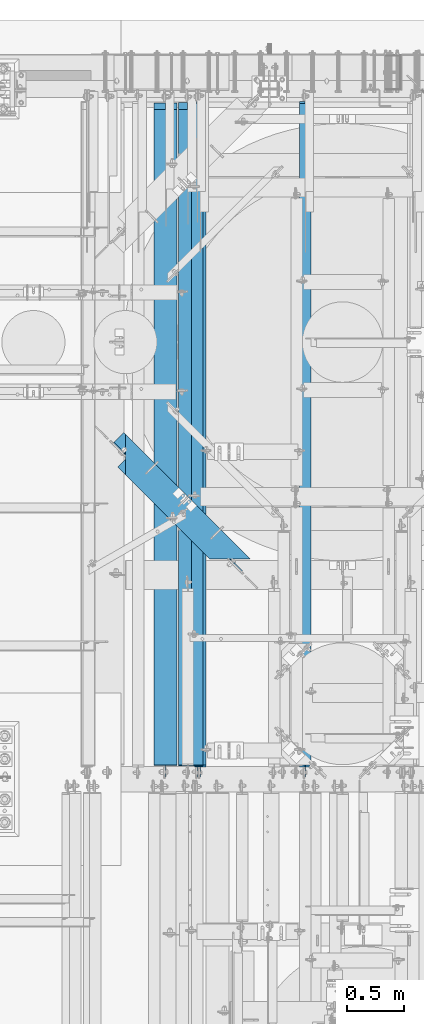
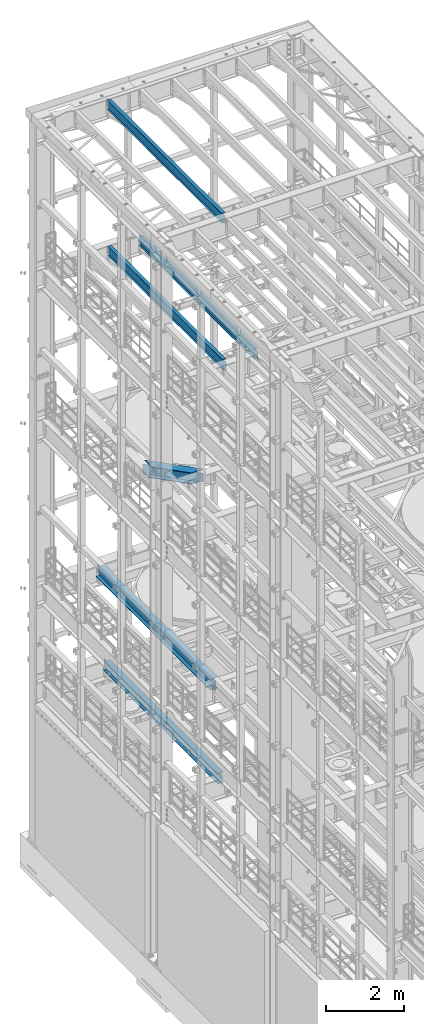
# One storey, part 1051 of 1876: 6 beams, 6 elements without a shape of their own.
"""IFC2X3 building model written with IfcOpenShell, lengths in millimetres."""

from ifc_helpers import new_model, si_unit, frame, origin_with_axes, place, context, subcontext, project, spatial, faceted_brep, material, type_object, element, aggregate, save


model = new_model("IFC2X3")

# Units and contexts
model_context = context("Model", 3, precision=1e-05, world=origin_with_axes())
body_context = subcontext(model_context, "Body", "Model", "MODEL_VIEW")
ifc_project = project(units=[si_unit("LENGTHUNIT", "METRE", prefix="MILLI"), si_unit("AREAUNIT", "SQUARE_METRE"), si_unit("VOLUMEUNIT", "CUBIC_METRE"), si_unit("MASSUNIT", "GRAM", prefix="KILO"), si_unit("TIMEUNIT", "SECOND"), si_unit("PLANEANGLEUNIT", "RADIAN"), si_unit("SOLIDANGLEUNIT", "STERADIAN"), si_unit("THERMODYNAMICTEMPERATUREUNIT", "DEGREE_CELSIUS"), si_unit("LUMINOUSINTENSITYUNIT", "LUMEN")], contexts=[model_context])

# Site, building, storey
site_placement = place(None, origin_with_axes())
site = spatial("IfcSite", under=ifc_project, at=site_placement, CompositionType="ELEMENT")
building_placement = place(site_placement, origin_with_axes())
building = spatial("IfcBuilding", under=site, at=building_placement, Name="Undefined", CompositionType="ELEMENT")
storey_placement = place(building_placement, origin_with_axes())
storey = spatial("IfcBuildingStorey", under=building, at=storey_placement, Name="Undefined", CompositionType="ELEMENT", Elevation=0.0)

# Assembly, beam
assembly_1_placement = place(storey_placement, origin_with_axes())
assembly_1 = element("IfcElementAssembly", 1, at=assembly_1_placement, inside=storey, Name="BEAM", AssemblyPlace="NOTDEFINED", PredefinedType="RIGID_FRAME")
ifc_material = material(Name="STEEL/A992")
beam_type_1 = type_object("IfcBeamType", Name="W12X16", PredefinedType="NOTDEFINED")
beam_1_placement = place(assembly_1_placement, frame((2857.5, 7620.0, 17830.8), z_axis=(0.0, 0.0, 1.0), x_axis=(0.0, 1.0, 0.0)))
beam_1 = element("IfcBeam", 2, at=beam_1_placement, type_object=beam_type_1, material=ifc_material, Name="BEAM", ObjectType="W12X16", context=body_context, shape_type="Brep", body=[
    faceted_brep([(19.84375, -3.17499999999995, -126.999999999996), (19.84375, 3.17499999999995, -126.999999999996), (96.0437501907345, 3.17500002364682, -126.999999999996), (96.0437501907345, -3.17499999999995, -126.999999999996), (100.90382970878, 3.17500002380461, -127.966729922584), (100.90382970878, -3.17499999999995, -127.966729922584), (105.024006176934, 3.17500002425209, -130.719743823061), (105.024006176934, -3.17499999999995, -130.719743823061), (107.777020077412, 3.17500002492102, -134.839920291215), (107.777020077412, -3.17499999999995, -134.839920291215), (108.74375, -3.17499999999995, -139.699999809261), (108.74375, 3.17500002570978, -139.699999809261), (108.74375, 3.17500009516311, -146.049999999999), (108.74375, 50.8, -146.049999999999), (108.74375, 50.8, -152.400000000001), (108.74375, -50.8, -152.400000000001), (108.74375, -50.8, -146.049999999999), (108.74375, -3.17499999999995, -146.049999999999), (5969.79375, 50.8, 146.049999999999), (5969.79375, 3.17499999999995, 146.049999999999), (126.20625, 3.17499999999995, 146.049999999999), (126.20625, 50.8, 146.049999999999), (113.506250190735, -3.17499999999995, 107.950000000004), (113.506250190735, 3.17499998606149, 107.950000000004), (19.84375, 3.17499999999995, 107.950000000004), (19.84375, -3.17499999999995, 107.950000000004), (118.366329708781, -3.17499999999995, 108.916729922592), (118.366329708781, 3.17499998590552, 108.916729922592), (122.486506176934, -3.17499999999995, 111.669743823069), (122.486506176934, 3.17499998546009, 111.669743823069), (125.239520077413, -3.17499999999995, 115.789920291223), (125.239520077413, 3.17499998479298, 115.789920291223), (126.20625, -3.17499999999995, 120.64999980927), (126.20625, 3.17499998400558, 120.64999980927), (5969.79375, -50.8, 152.400000000001), (5969.79375, 50.8, 152.400000000001), (126.20625, 50.8, 152.400000000001), (126.20625, -50.8, 152.400000000001), (5969.79375, -50.8, 146.049999999999), (126.20625, -50.8, 146.049999999999), (5969.79375, -3.17499999999995, 146.049999999999), (126.20625, -3.17499999999995, 146.049999999999), (5969.79375, -3.17499999999995, 120.64999980927), (5969.79375, 3.17499999999995, 120.64999980927), (5970.76047992259, -3.17499999999995, 115.789920291223), (5970.76047992259, 3.17499999999995, 115.789920291223), (5973.51349382307, -3.17499999999995, 111.669743823069), (5973.51349382307, 3.17499999999995, 111.669743823069), (5977.63367029122, -3.17499999999995, 108.916729922592), (5977.63367029122, 3.17499999999995, 108.916729922592), (5982.49374980927, -3.17499999999995, 107.950000000004), (5982.49374980927, 3.17499999999995, 107.950000000004), (6076.15625, -3.17499999999995, 107.950000000004), (6076.15625, 3.17499999999995, 107.950000000004), (6076.15625, -3.17499999999995, -126.999999999996), (6076.15625, 3.17499999999995, -126.999999999996), (5999.95624980926, -3.17499999999995, -126.999999999996), (5999.95624980926, 3.17499999999995, -126.999999999996), (5995.09617029122, -3.17499999999995, -127.966729922584), (5995.09617029122, 3.17499999999995, -127.966729922584), (5990.97599382306, -3.17499999999995, -130.719743823061), (5990.97599382306, 3.17499999999995, -130.719743823061), (5988.22297992259, -3.17499999999995, -134.839920291215), (5988.22297992259, 3.17499999999995, -134.839920291215), (5987.25625, -3.17499999999995, -139.699999809261), (5987.25625, 3.17499999999995, -139.699999809261), (5987.25625, -3.17499999999995, -146.049999999999), (5987.25625, -50.8, -146.049999999999), (5987.25625, -50.8, -152.400000000001), (5987.25625, 50.8, -152.400000000001), (5987.25625, 50.8, -146.049999999999), (5987.25625, 3.17499999999995, -146.049999999999)], [[[0, 1, 2, 3]], [[3, 2, 4, 5]], [[5, 4, 6, 7]], [[7, 6, 8, 9]], [[10, 11, 12, 13, 14, 15, 16, 17]], [[9, 8, 11, 10]], [[18, 19, 20, 21]], [[22, 23, 24, 25]], [[26, 27, 23, 22]], [[28, 29, 27, 26]], [[30, 31, 29, 28]], [[32, 33, 31, 30]], [[34, 35, 36, 37]], [[38, 34, 37, 39]], [[40, 38, 39, 41]], [[37, 36, 21, 20, 33, 32, 41, 39]], [[35, 18, 21, 36]], [[34, 38, 40, 42, 43, 19, 18, 35]], [[44, 45, 43, 42]], [[46, 47, 45, 44]], [[48, 49, 47, 46]], [[50, 51, 49, 48]], [[52, 53, 51, 50]], [[53, 52, 54, 55]], [[54, 56, 57, 55]], [[58, 59, 57, 56]], [[60, 61, 59, 58]], [[62, 63, 61, 60]], [[64, 65, 63, 62]], [[66, 67, 68, 69, 70, 71, 65, 64]], [[67, 66, 17, 16]], [[68, 67, 16, 15]], [[69, 68, 15, 14]], [[70, 69, 14, 13]], [[71, 70, 13, 12]], [[6, 4, 2, 1, 24, 23, 27, 29, 31, 33, 20, 19, 43, 45, 47, 49, 51, 53, 55, 57, 59, 61, 63, 65, 71, 12, 11, 8]], [[25, 24, 1, 0]], [[66, 64, 62, 60, 58, 56, 54, 52, 50, 48, 46, 44, 42, 40, 41, 32, 30, 28, 26, 22, 25, 0, 3, 5, 7, 9, 10, 17]]]),
])
aggregate(assembly_1, [beam_1])

assembly_2_placement = place(storey_placement, origin_with_axes())
assembly_2 = element("IfcElementAssembly", 3, at=assembly_2_placement, inside=storey, Name="BEAM", AssemblyPlace="NOTDEFINED", PredefinedType="RIGID_FRAME")
beam_2_placement = place(assembly_2_placement, frame((1930.4, 7620.0, 17830.8), z_axis=(0.0, 0.0, 1.0), x_axis=(0.0, 1.0, 0.0)))
beam_2 = element("IfcBeam", 4, at=beam_2_placement, type_object=beam_type_1, material=ifc_material, Name="BEAM", ObjectType="W12X16", context=body_context, shape_type="Brep", body=[
    faceted_brep([(19.84375, -3.17499999999995, -126.999999999996), (19.84375, 3.17499999999995, -126.999999999996), (96.0437501907345, 3.17500002364682, -126.999999999996), (96.0437501907345, -3.17499999999995, -126.999999999996), (100.90382970878, 3.17500002380461, -127.966729922584), (100.90382970878, -3.17499999999995, -127.966729922584), (105.024006176934, 3.17500002425209, -130.719743823061), (105.024006176934, -3.17499999999995, -130.719743823061), (107.777020077412, 3.17500002492102, -134.839920291215), (107.777020077412, -3.17499999999995, -134.839920291215), (108.74375, -3.17499999999995, -139.699999809261), (108.74375, 3.17500002570978, -139.699999809261), (108.74375, 3.17500009516311, -146.049999999999), (108.74375, 50.8, -146.049999999999), (108.74375, 50.8, -152.400000000001), (108.74375, -50.8, -152.400000000001), (108.74375, -50.8, -146.049999999999), (108.74375, -3.17499999999995, -146.049999999999), (5969.79375, 50.8, 146.049999999999), (5969.79375, 3.17499999999995, 146.049999999999), (126.20625, 3.17499999999995, 146.049999999999), (126.20625, 50.8, 146.049999999999), (113.506250190735, -3.17499999999995, 107.950000000004), (113.506250190735, 3.17499998606149, 107.950000000004), (19.84375, 3.17499999999995, 107.950000000004), (19.84375, -3.17499999999995, 107.950000000004), (118.366329708781, -3.17499999999995, 108.916729922592), (118.366329708781, 3.17499998590552, 108.916729922592), (122.486506176934, -3.17499999999995, 111.669743823069), (122.486506176934, 3.17499998546009, 111.669743823069), (125.239520077413, -3.17499999999995, 115.789920291223), (125.239520077413, 3.17499998479298, 115.789920291223), (126.20625, -3.17499999999995, 120.64999980927), (126.20625, 3.17499998400558, 120.64999980927), (5969.79375, -50.8, 152.400000000001), (5969.79375, 50.8, 152.400000000001), (126.20625, 50.8, 152.400000000001), (126.20625, -50.8, 152.400000000001), (5969.79375, -50.8, 146.049999999999), (126.20625, -50.8, 146.049999999999), (5969.79375, -3.17499999999995, 146.049999999999), (126.20625, -3.17499999999995, 146.049999999999), (5969.79375, -3.17499999999995, 120.64999980927), (5969.79375, 3.17499999999995, 120.64999980927), (5970.76047992259, -3.17499999999995, 115.789920291223), (5970.76047992259, 3.17499999999995, 115.789920291223), (5973.51349382307, -3.17499999999995, 111.669743823069), (5973.51349382307, 3.17499999999995, 111.669743823069), (5977.63367029122, -3.17499999999995, 108.916729922592), (5977.63367029122, 3.17499999999995, 108.916729922592), (5982.49374980927, -3.17499999999995, 107.950000000004), (5982.49374980927, 3.17499999999995, 107.950000000004), (6076.15625, -3.17499999999995, 107.950000000004), (6076.15625, 3.17499999999995, 107.950000000004), (6076.15625, -3.17499999999995, -126.999999999996), (6076.15625, 3.17499999999995, -126.999999999996), (5999.95624980926, -3.17499999999995, -126.999999999996), (5999.95624980926, 3.17499999999995, -126.999999999996), (5995.09617029122, -3.17499999999995, -127.966729922584), (5995.09617029122, 3.17499999999995, -127.966729922584), (5990.97599382306, -3.17499999999995, -130.719743823061), (5990.97599382306, 3.17499999999995, -130.719743823061), (5988.22297992259, -3.17499999999995, -134.839920291215), (5988.22297992259, 3.17499999999995, -134.839920291215), (5987.25625, -3.17499999999995, -139.699999809261), (5987.25625, 3.17499999999995, -139.699999809261), (5987.25625, -3.17499999999995, -146.049999999999), (5987.25625, -50.8, -146.049999999999), (5987.25625, -50.8, -152.400000000001), (5987.25625, 50.8, -152.400000000001), (5987.25625, 50.8, -146.049999999999), (5987.25625, 3.17499999999995, -146.049999999999)], [[[0, 1, 2, 3]], [[3, 2, 4, 5]], [[5, 4, 6, 7]], [[7, 6, 8, 9]], [[10, 11, 12, 13, 14, 15, 16, 17]], [[9, 8, 11, 10]], [[18, 19, 20, 21]], [[22, 23, 24, 25]], [[26, 27, 23, 22]], [[28, 29, 27, 26]], [[30, 31, 29, 28]], [[32, 33, 31, 30]], [[34, 35, 36, 37]], [[38, 34, 37, 39]], [[40, 38, 39, 41]], [[37, 36, 21, 20, 33, 32, 41, 39]], [[35, 18, 21, 36]], [[34, 38, 40, 42, 43, 19, 18, 35]], [[44, 45, 43, 42]], [[46, 47, 45, 44]], [[48, 49, 47, 46]], [[50, 51, 49, 48]], [[52, 53, 51, 50]], [[53, 52, 54, 55]], [[54, 56, 57, 55]], [[58, 59, 57, 56]], [[60, 61, 59, 58]], [[62, 63, 61, 60]], [[64, 65, 63, 62]], [[66, 67, 68, 69, 70, 71, 65, 64]], [[67, 66, 17, 16]], [[68, 67, 16, 15]], [[69, 68, 15, 14]], [[70, 69, 14, 13]], [[71, 70, 13, 12]], [[6, 4, 2, 1, 24, 23, 27, 29, 31, 33, 20, 19, 43, 45, 47, 49, 51, 53, 55, 57, 59, 61, 63, 65, 71, 12, 11, 8]], [[25, 24, 1, 0]], [[66, 64, 62, 60, 58, 56, 54, 52, 50, 48, 46, 44, 42, 40, 41, 32, 30, 28, 26, 22, 25, 0, 3, 5, 7, 9, 10, 17]]]),
])
aggregate(assembly_2, [beam_2])

assembly_3_placement = place(storey_placement, origin_with_axes())
assembly_3 = element("IfcElementAssembly", 5, at=assembly_3_placement, inside=storey, Name="BEAM", AssemblyPlace="NOTDEFINED", PredefinedType="RIGID_FRAME")
beam_3_placement = place(assembly_3_placement, frame((1905.0, 7620.0, 22402.8), z_axis=(0.0, 0.0, 1.0), x_axis=(0.0, 1.0, 0.0)))
beam_3 = element("IfcBeam", 6, at=beam_3_placement, type_object=beam_type_1, material=ifc_material, Name="BEAM", ObjectType="W12X16", context=body_context, shape_type="Brep", body=[
    faceted_brep([(19.84375, -3.17499999999995, -126.999999999996), (19.84375, 3.17499999999995, -126.999999999996), (102.393750190735, 3.17500000000018, -127.000000000001), (102.393750190735, -3.17500000000018, -127.000000000001), (107.25382970878, 3.17500000000018, -127.966729922588), (107.25382970878, -3.17500000000018, -127.966729922588), (111.374006176934, 3.17500000000018, -130.719743823067), (111.374006176934, -3.17500000000018, -130.719743823067), (114.127020077412, 3.17500000000018, -134.839920291221), (114.127020077412, -3.17500000000018, -134.839920291221), (115.09375, -3.17500000000018, -139.699999809266), (115.09375, 3.17500000000018, -139.699999809266), (115.09375, 3.17500000000018, -146.05), (115.09375, 50.8000000000002, -146.05), (115.09375, 50.8000000000002, -152.4), (115.09375, -50.8000000000002, -152.4), (115.09375, -50.8000000000002, -146.05), (115.09375, -3.17500000000018, -146.05), (127.79375, 3.17500000000018, 146.05), (127.79375, 50.8000000000002, 146.05), (5968.20625, 50.8, 146.05), (5968.20625, 3.17499999999995, 146.05), (115.093750190735, -3.17500000000018, 114.299999999999), (115.093750190735, 3.17500000000018, 114.299999999999), (19.84375, 3.17500000000018, 114.299999999999), (19.84375, -3.17500000000018, 114.299999999999), (119.95382970878, -3.17500000000018, 115.266729922587), (119.95382970878, 3.17500000000018, 115.266729922587), (124.074006176934, -3.17500000000018, 118.019743823065), (124.074006176934, 3.17500000000018, 118.019743823065), (126.827020077412, -3.17500000000018, 122.139920291219), (126.827020077412, 3.17500000000018, 122.139920291219), (127.79375, -3.17500000000018, 126.999999809264), (127.79375, 3.17500000000018, 126.999999809264), (127.79375, 50.8000000000002, 152.4), (127.79375, -50.8000000000002, 152.4), (5968.20625, -50.8, 152.4), (5968.20625, 50.8, 152.4), (127.79375, -50.8000000000002, 146.05), (5968.20625, -50.8, 146.05), (127.79375, -3.17500000000018, 146.05), (5968.20625, -3.17499999999995, 146.05), (5968.20625, -3.17499999999995, 126.999999809264), (5968.20625, 3.17499999999995, 126.999999809264), (5969.17297992259, -3.17499999999995, 122.139920291219), (5969.17297992259, 3.17499999999995, 122.139920291219), (5971.92599382307, -3.17499999999995, 118.019743823065), (5971.92599382307, 3.17499999999995, 118.019743823065), (5976.04617029122, -3.17499999999995, 115.266729922587), (5976.04617029122, 3.17499999999995, 115.266729922587), (5980.90624980927, -3.17499999999995, 114.299999999999), (5980.90624980927, 3.17499999999995, 114.299999999999), (6076.15625, -3.17499999999995, 114.299999999999), (6076.15625, 3.17499999999995, 114.299999999999), (6076.15625, -3.17499999999995, -126.999999999996), (6076.15625, 3.17499999999995, -126.999999999996), (5993.60624980927, -3.17499999999995, -127.000000000001), (5993.60624980927, 3.17499999999995, -127.000000000001), (5988.74617029122, -3.17499999999995, -127.966729922588), (5988.74617029122, 3.17499999999995, -127.966729922588), (5984.62599382307, -3.17499999999995, -130.719743823067), (5984.62599382307, 3.17499999999995, -130.719743823067), (5981.87297992259, -3.17499999999995, -134.839920291221), (5981.87297992259, 3.17499999999995, -134.839920291221), (5980.90625, -3.17499999999995, -139.699999809266), (5980.90625, 3.17499999999995, -139.699999809266), (5980.90625, -3.17499999999995, -146.05), (5980.90625, -50.8, -146.05), (5980.90625, -50.8, -152.4), (5980.90625, 50.8, -152.4), (5980.90625, 50.8, -146.05), (5980.90625, 3.17499999999995, -146.05)], [[[0, 1, 2, 3]], [[3, 2, 4, 5]], [[5, 4, 6, 7]], [[7, 6, 8, 9]], [[10, 11, 12, 13, 14, 15, 16, 17]], [[9, 8, 11, 10]], [[18, 19, 20, 21]], [[22, 23, 24, 25]], [[26, 27, 23, 22]], [[28, 29, 27, 26]], [[30, 31, 29, 28]], [[32, 33, 31, 30]], [[34, 35, 36, 37]], [[35, 38, 39, 36]], [[38, 40, 41, 39]], [[35, 34, 19, 18, 33, 32, 40, 38]], [[19, 34, 37, 20]], [[36, 39, 41, 42, 43, 21, 20, 37]], [[44, 45, 43, 42]], [[46, 47, 45, 44]], [[48, 49, 47, 46]], [[50, 51, 49, 48]], [[52, 53, 51, 50]], [[53, 52, 54, 55]], [[54, 56, 57, 55]], [[58, 59, 57, 56]], [[60, 61, 59, 58]], [[62, 63, 61, 60]], [[64, 65, 63, 62]], [[66, 67, 68, 69, 70, 71, 65, 64]], [[17, 16, 67, 66]], [[16, 15, 68, 67]], [[15, 14, 69, 68]], [[14, 13, 70, 69]], [[13, 12, 71, 70]], [[59, 61, 63, 65, 71, 12, 11, 8, 6, 4, 2, 1, 24, 23, 27, 29, 31, 33, 18, 21, 43, 45, 47, 49, 51, 53, 55, 57]], [[25, 24, 1, 0]], [[52, 50, 48, 46, 44, 42, 41, 40, 32, 30, 28, 26, 22, 25, 0, 3, 5, 7, 9, 10, 17, 66, 64, 62, 60, 58, 56, 54]]]),
])
aggregate(assembly_3, [beam_3])

assembly_4_placement = place(storey_placement, origin_with_axes())
assembly_4 = element("IfcElementAssembly", 7, at=assembly_4_placement, inside=storey, Name="BEAM", AssemblyPlace="NOTDEFINED", PredefinedType="RIGID_FRAME")
beam_type_2 = type_object("IfcBeamType", Name="W12X30", PredefinedType="NOTDEFINED")
beam_4_placement = place(assembly_4_placement, frame((1822.45, 7620.0000000019, 4973.6375), z_axis=(0.0, 0.0, 1.0), x_axis=(0.0, 1.0, 0.0)))
beam_4 = element("IfcBeam", 8, at=beam_4_placement, type_object=beam_type_2, material=ifc_material, Name="BEAM", ObjectType="W12X30", context=body_context, shape_type="Brep", body=[
    faceted_brep([(19.8437500000002, -3.17500000000018, -131.762499999993), (19.8437500000002, 3.17500000000018, -131.762499999993), (102.393750190735, 3.17500000000018, -131.762500000001), (102.393750190735, -3.17500000000018, -131.762500000001), (107.25382970878, 3.17500000000018, -132.729229922588), (107.25382970878, -3.17500000000018, -132.729229922588), (111.374006176934, 3.17500000000018, -135.482243823067), (111.374006176934, -3.17500000000018, -135.482243823067), (114.127020077412, 3.17500000000018, -139.60242029122), (114.127020077412, -3.17500000000018, -139.60242029122), (115.09375, -3.17500000000018, -144.462499809266), (115.09375, 3.17500000000018, -144.462499809266), (115.09375, 3.17500000000018, -146.05), (115.09375, 82.5500000000002, -146.05), (115.09375, 82.5500000000002, -157.1625), (115.09375, -82.5500000000002, -157.1625), (115.09375, -82.5500000000002, -146.05), (115.09375, -3.17500000000018, -146.05), (5914.23125, 82.5500000000002, 146.05), (5914.23125, 3.17500000000018, 146.05), (127.79375, 3.17500000000018, 146.05), (127.793782276814, 82.5500000000102, 146.05), (115.09374930124, -3.17499999999995, 119.062500000004), (115.09374930124, 3.17499999999995, 119.062500000004), (19.8437491105051, 3.17499999999995, 119.062500000004), (19.8437491105051, -3.17499999999995, 119.062500000004), (119.953828819285, -3.17499999999995, 120.029229922591), (119.953828819285, 3.17499999999995, 120.029229922591), (124.074005287439, -3.17499999999995, 122.782243823069), (124.074005287439, 3.17499999999995, 122.782243823069), (126.827019187917, -3.17499999999995, 126.902420291222), (126.827019187917, 3.17499999999995, 126.902420291222), (127.793749110505, -3.17499999999995, 131.762499809269), (127.793749110505, 3.17499999999995, 131.762499809269), (5914.23125, -82.5500000000002, 157.1625), (5914.23125, 82.5500000000002, 157.1625), (127.793749110505, 82.55, 157.162499999999), (127.793749110505, -82.55, 157.162499999999), (5914.23125, -82.5500000000002, 146.05), (127.793782276821, -82.5500000000029, 146.05), (5914.23125, -3.17500000000018, 146.05), (127.79375, -3.17500000000018, 146.05), (5914.23125, -3.17500000000018, 119.062499809265), (5914.23125, 3.17500000000018, 119.062499809265), (5915.19797992259, -3.17500000000018, 114.20242029122), (5915.19797992259, 3.17500000000018, 114.20242029122), (5917.95099382307, -3.17500000000018, 110.082243823066), (5917.95099382307, 3.17500000000018, 110.082243823066), (5922.07117029122, -3.17500000000018, 107.329229922588), (5922.07117029122, 3.17500000000018, 107.329229922588), (5926.93124980926, -3.17500000000018, 106.3625), (5926.93124980926, 3.17500000000018, 106.3625), (6072.98125, -3.17500000000018, 106.3625), (6072.98125, 3.17500000000018, 106.3625), (6072.98125, -3.17500000000018, -131.7625), (6072.98125, 3.17500000000018, -131.7625), (5990.43124980926, -3.17500000000018, -131.7625), (5990.43124980926, 3.17500000000018, -131.7625), (5985.57117029122, -3.17500000000018, -132.729229922587), (5985.57117029122, 3.17500000000018, -132.729229922587), (5981.45099382307, -3.17500000000018, -135.482243823066), (5981.45099382307, 3.17500000000018, -135.482243823066), (5978.69797992259, -3.17500000000018, -139.602420291219), (5978.69797992259, 3.17500000000018, -139.602420291219), (5977.73125, -3.17500000000018, -144.462499809265), (5977.73125, 3.17500000000018, -144.462499809265), (5977.73125, -3.17500000000018, -146.05), (5977.73125, -82.5500000000002, -146.05), (5977.73125, -82.5500000000002, -157.1625), (5977.73125, 82.5500000000002, -157.1625), (5977.73125, 82.5500000000002, -146.05), (5977.73125, 3.17500000000018, -146.05)], [[[0, 1, 2, 3]], [[3, 2, 4, 5]], [[5, 4, 6, 7]], [[7, 6, 8, 9]], [[10, 11, 12, 13, 14, 15, 16, 17]], [[9, 8, 11, 10]], [[18, 19, 20, 21]], [[22, 23, 24, 25]], [[26, 27, 23, 22]], [[28, 29, 27, 26]], [[30, 31, 29, 28]], [[32, 33, 31, 30]], [[34, 35, 36, 37]], [[38, 34, 37, 39]], [[40, 38, 39, 41]], [[37, 36, 21, 20, 33, 32, 41, 39]], [[35, 18, 21, 36]], [[34, 38, 40, 42, 43, 19, 18, 35]], [[44, 45, 43, 42]], [[46, 47, 45, 44]], [[48, 49, 47, 46]], [[50, 51, 49, 48]], [[52, 53, 51, 50]], [[53, 52, 54, 55]], [[54, 56, 57, 55]], [[58, 59, 57, 56]], [[60, 61, 59, 58]], [[62, 63, 61, 60]], [[64, 65, 63, 62]], [[66, 67, 68, 69, 70, 71, 65, 64]], [[67, 66, 17, 16]], [[68, 67, 16, 15]], [[69, 68, 15, 14]], [[70, 69, 14, 13]], [[71, 70, 13, 12]], [[6, 4, 2, 1, 24, 23, 27, 29, 31, 33, 20, 19, 43, 45, 47, 49, 51, 53, 55, 57, 59, 61, 63, 65, 71, 12, 11, 8]], [[25, 24, 1, 0]], [[66, 64, 62, 60, 58, 56, 54, 52, 50, 48, 46, 44, 42, 40, 41, 32, 30, 28, 26, 22, 25, 0, 3, 5, 7, 9, 10, 17]]]),
])
aggregate(assembly_4, [beam_4])

assembly_5_placement = place(storey_placement, origin_with_axes())
assembly_5 = element("IfcElementAssembly", 9, at=assembly_5_placement, inside=storey, Name="BEAM", AssemblyPlace="NOTDEFINED", PredefinedType="RIGID_FRAME")
beam_type_3 = type_object("IfcBeamType", Name="W14X48", PredefinedType="NOTDEFINED")
beam_5_placement = place(assembly_5_placement, frame((1625.6, 7620.0, 7978.775), z_axis=(0.0, 0.0, 1.0), x_axis=(0.0, 1.0, 0.0)))
beam_5 = element("IfcBeam", 10, at=beam_5_placement, type_object=beam_type_3, material=ifc_material, Name="BEAM", ObjectType="W14X48", context=body_context, shape_type="Brep", body=[
    faceted_brep([(19.84375, -3.96875, -142.875000000001), (19.84375, 3.96875, -142.875000000001), (108.743750190735, 3.96875, -142.875000000001), (108.743750190735, -3.96875, -142.875000000001), (113.603829708781, 3.96875, -143.841729922588), (113.603829708781, -3.96875, -143.841729922588), (117.724006176934, 3.96875, -146.594743823067), (117.724006176934, -3.96875, -146.594743823067), (120.477020077413, 3.96875, -150.714920291221), (120.477020077413, -3.96875, -150.714920291221), (121.44375, -3.96875, -155.574999809266), (121.44375, 3.96875, -155.574999809266), (121.44375, 3.96875, -158.75), (121.44375, 101.6, -158.75), (121.443749999999, 101.6, -174.625), (121.443749999999, -101.6, -174.625), (121.44375, -101.6, -158.75), (121.44375, -3.96875, -158.75), (5914.23125, 101.6, 158.75), (5914.23125, 3.96875, 158.75), (127.79375, 3.96875, 158.75), (127.79375, 101.6, 158.75), (115.093750190735, -3.96875, 136.524999999999), (115.093750190735, 3.96875, 136.524999999999), (19.8437500000002, 3.96875, 136.524999999999), (19.8437500000002, -3.96875, 136.524999999999), (119.95382970878, -3.96875, 137.491729922586), (119.95382970878, 3.96875, 137.491729922586), (124.074006176934, -3.96875, 140.244743823065), (124.074006176934, 3.96875, 140.244743823065), (126.827020077412, -3.96875, 144.364920291218), (126.827020077412, 3.96875, 144.364920291218), (127.79375, -3.96875, 149.224999809264), (127.79375, 3.96875, 149.224999809264), (5914.23125, -101.6, 174.625), (5914.23125, 101.6, 174.625), (127.79375, 101.6, 174.625), (127.79375, -101.6, 174.625), (5914.23125, -101.6, 158.75), (127.79375, -101.6, 158.75), (5914.23125, -3.96875, 158.75), (127.79375, -3.96875, 158.75), (5914.23125, -3.96875, 136.524999809265), (5914.23125, 3.96875, 136.524999809265), (5915.19797992259, -3.96875, 131.664920291219), (5915.19797992259, 3.96875, 131.664920291219), (5917.95099382307, -3.96875, 127.544743823066), (5917.95099382307, 3.96875, 127.544743823066), (5922.07117029122, -3.96875, 124.791729922587), (5922.07117029122, 3.96875, 124.791729922587), (5926.93124980926, -3.96875, 123.825), (5926.93124980926, 3.96875, 123.825), (6072.98125, -3.96875, 123.825), (6072.98125, 3.96875, 123.825), (6072.98125, -3.96875, -142.875), (6072.98125, 3.96875, -142.875), (5984.08124980926, -3.96875, -142.875), (5984.08124980926, 3.96875, -142.875), (5979.22117029122, -3.96875, -143.841729922588), (5979.22117029122, 3.96875, -143.841729922588), (5975.10099382306, -3.96875, -146.594743823066), (5975.10099382306, 3.96875, -146.594743823066), (5972.34797992259, -3.96875, -150.71492029122), (5972.34797992259, 3.96875, -150.71492029122), (5971.38125, -3.96875, -155.574999809265), (5971.38125, 3.96875, -155.574999809265), (5971.38125, -3.96875, -158.75), (5971.38125, -101.6, -158.75), (5971.38125, -101.6, -174.625), (5971.38125, 101.6, -174.625), (5971.38125, 101.6, -158.75), (5971.38125, 3.96875, -158.75)], [[[0, 1, 2, 3]], [[3, 2, 4, 5]], [[5, 4, 6, 7]], [[7, 6, 8, 9]], [[10, 11, 12, 13, 14, 15, 16, 17]], [[9, 8, 11, 10]], [[18, 19, 20, 21]], [[22, 23, 24, 25]], [[26, 27, 23, 22]], [[28, 29, 27, 26]], [[30, 31, 29, 28]], [[32, 33, 31, 30]], [[34, 35, 36, 37]], [[38, 34, 37, 39]], [[40, 38, 39, 41]], [[37, 36, 21, 20, 33, 32, 41, 39]], [[35, 18, 21, 36]], [[34, 38, 40, 42, 43, 19, 18, 35]], [[44, 45, 43, 42]], [[46, 47, 45, 44]], [[48, 49, 47, 46]], [[50, 51, 49, 48]], [[52, 53, 51, 50]], [[53, 52, 54, 55]], [[54, 56, 57, 55]], [[58, 59, 57, 56]], [[60, 61, 59, 58]], [[62, 63, 61, 60]], [[64, 65, 63, 62]], [[66, 67, 68, 69, 70, 71, 65, 64]], [[67, 66, 17, 16]], [[68, 67, 16, 15]], [[69, 68, 15, 14]], [[70, 69, 14, 13]], [[71, 70, 13, 12]], [[6, 4, 2, 1, 24, 23, 27, 29, 31, 33, 20, 19, 43, 45, 47, 49, 51, 53, 55, 57, 59, 61, 63, 65, 71, 12, 11, 8]], [[25, 24, 1, 0]], [[66, 64, 62, 60, 58, 56, 54, 52, 50, 48, 46, 44, 42, 40, 41, 32, 30, 28, 26, 22, 25, 0, 3, 5, 7, 9, 10, 17]]]),
])
aggregate(assembly_5, [beam_5])

assembly_6_placement = place(storey_placement, origin_with_axes())
assembly_6 = element("IfcElementAssembly", 11, at=assembly_6_placement, inside=storey, Name="BEAM", AssemblyPlace="NOTDEFINED", PredefinedType="RIGID_FRAME")
beam_type_4 = type_object("IfcBeamType", Name="W14X68", PredefinedType="NOTDEFINED")
beam_6_placement = place(assembly_6_placement, frame((1098.59673643742, 10660.1092268362, 13131.8), z_axis=(0.0, 0.0, 1.0), x_axis=(0.707106781186547, -0.707106781186548, 0.0)))
beam_6 = element("IfcBeam", 12, at=beam_6_placement, type_object=beam_type_4, material=ifc_material, Name="BEAM", ObjectType="W14X68", context=body_context, shape_type="Brep", body=[
    faceted_brep([(266.29144209256, -5.55625000004511, -158.75), (266.29144209256, -5.55627010486569, -177.799999999999), (273.435192092567, -5.55625009733558, -177.799999999999), (273.435192092566, -5.55625000004511, -158.75), (273.435192092694, -127.000003302121, -158.75), (273.435192092695, -127.000000000046, -177.799999999999), (93.456206786278, 126.999999999985, -177.799999999999), (93.456206786278, 126.999999999985, -158.75), (1678.40532448611, 126.999999999731, -158.75), (1678.40532448611, 126.999999999731, -177.799999999999), (93.4559663399787, 5.55624999998327, -158.75), (1556.96157448613, 5.55624999974862, -158.75), (1574.92208645853, 5.55624999974498, -133.35), (1563.80958645853, -5.55625000025248, -133.35), (1556.9363960899, -5.55625000025248, -134.316729922588), (1568.0488960899, 5.55624999974862, -134.316729922588), (1551.10958664927, -5.55625000025066, -137.069743823065), (1562.22208664927, 5.5562499997468, -137.069743823065), (1547.21623705381, -5.55625000025066, -141.189920291219), (1558.32873705381, 5.55624999974862, -141.189920291219), (1545.84907448613, -5.55625000025066, -146.049999809266), (1556.96157448613, 5.55624999975043, -146.049999809266), (1545.84907448613, -5.55625000025066, -158.75), (1424.40532409695, -127.000000389435, -158.75), (1424.40532448615, -127.000000000232, -177.799999999999), (93.4559443406561, -5.55508857272798, -177.799999999999), (93.4559443383559, -5.55625000001601, -158.75), (93.4559443383559, -5.55625000001601, -124.299999999999), (93.4559443383559, -5.55625000001601, 130.915006484984), (93.4559443383559, -5.55625000001601, 133.35), (93.4559663399796, 5.55624999998327, 133.35), (227.751502909393, -5.55625000003783, 133.35), (216.63900290939, 5.55624999996508, 133.35), (234.624693278023, -5.55625000003965, 134.316729922588), (223.512193278021, 5.55624999996326, 134.316729922588), (240.451502718654, -5.55625000003965, 137.069743823065), (229.339002718653, 5.55624999996144, 137.069743823065), (244.344852314111, -5.55625000003965, 141.189920291219), (233.23235231411, 5.55624999996144, 141.189920291219), (245.712014881788, -5.55625000004147, 146.049999809266), (234.599514881786, 5.55624999996144, 146.049999809266), (367.155764881809, -127.000000000061, 177.799999999999), (113.155764881766, 126.999999999982, 177.799999999999), (113.155764881766, 126.999999999982, 158.75), (234.599514881785, 5.55624999996144, 158.75), (245.712014881788, -5.55625000004147, 158.75), (367.155764881809, -127.000000000061, 158.75), (1545.84907448801, -5.55625000025066, 158.75), (1424.40532448802, -127.00000000023, 158.75), (1424.40532448802, -127.00000000023, 177.799999999999), (1678.40532448799, 126.999999999731, 177.799999999999), (1678.40532448799, 126.999999999731, 158.75), (1556.961574488, 5.55624999974862, 158.75), (1545.84907448801, -5.55625000025066, 146.049999809266), (1556.961574488, 5.55624999974862, 146.049999809266), (1546.49369589632, -5.55625000025066, 143.758457181108), (1557.60619583345, 5.55624999974862, 143.758457404581), (1546.49369589636, -5.55625000025066, 137.0), (1557.6061958335, 5.55624999974862, 137.0), (1562.22208665114, 5.55624999974862, 137.069743823065), (1551.10958665114, -5.55625000025066, 137.069743823065), (1556.93639609177, -5.55625000025066, 134.316729922588), (1568.04889609177, 5.5562499997468, 134.316729922588), (1563.80958646041, -5.55625000025248, 133.35), (1574.9220864604, 5.55624999974498, 133.35), (1699.63596271373, -5.5562500002743, 133.35), (1699.63605997674, 5.55624999972679, 133.35), (1699.63596271373, -5.5562500002743, -132.50250038147), (1699.63596271373, -5.5562500002743, -133.35), (1699.63605997674, 5.55624999972679, -133.35)], [[[0, 1, 2, 3]], [[4, 3, 2, 5]], [[6, 7, 8, 9]], [[7, 10, 11, 8]], [[12, 13, 14, 15]], [[15, 14, 16, 17]], [[17, 16, 18, 19]], [[19, 18, 20, 21]], [[8, 11, 21, 20, 22, 23, 24, 9]], [[24, 23, 4, 5]], [[1, 25, 6, 9, 24, 5, 2]], [[26, 25, 1, 0]], [[27, 28, 29, 30, 10, 7, 6, 25, 26]], [[31, 32, 30, 29]], [[33, 34, 32, 31]], [[35, 36, 34, 33]], [[37, 38, 36, 35]], [[39, 40, 38, 37]], [[41, 42, 43, 44, 40, 39, 45, 46]], [[46, 45, 47, 48]], [[41, 46, 48, 49]], [[42, 41, 49, 50]], [[43, 42, 50, 51]], [[44, 43, 51, 52]], [[50, 49, 48, 47, 53, 54, 52, 51]], [[54, 53, 55, 56]], [[56, 55, 57, 58]], [[59, 58, 57, 60]], [[61, 62, 59, 60]], [[62, 61, 63, 64]], [[64, 63, 65, 66]], [[66, 65, 67, 68, 69]], [[15, 17, 19, 21, 11, 10, 30, 32, 34, 36, 38, 40, 44, 52, 54, 56, 58, 59, 62, 64, 66, 69, 12]], [[68, 13, 12, 69]], [[67, 65, 63, 61, 60, 57, 55, 53, 47, 45, 39, 37, 35, 33, 31, 29, 28, 27, 26, 0, 3, 22, 20, 18, 16, 14, 13, 68]], [[23, 22, 3, 4]]]),
])
aggregate(assembly_6, [beam_6])

save(model, "model.ifc")
